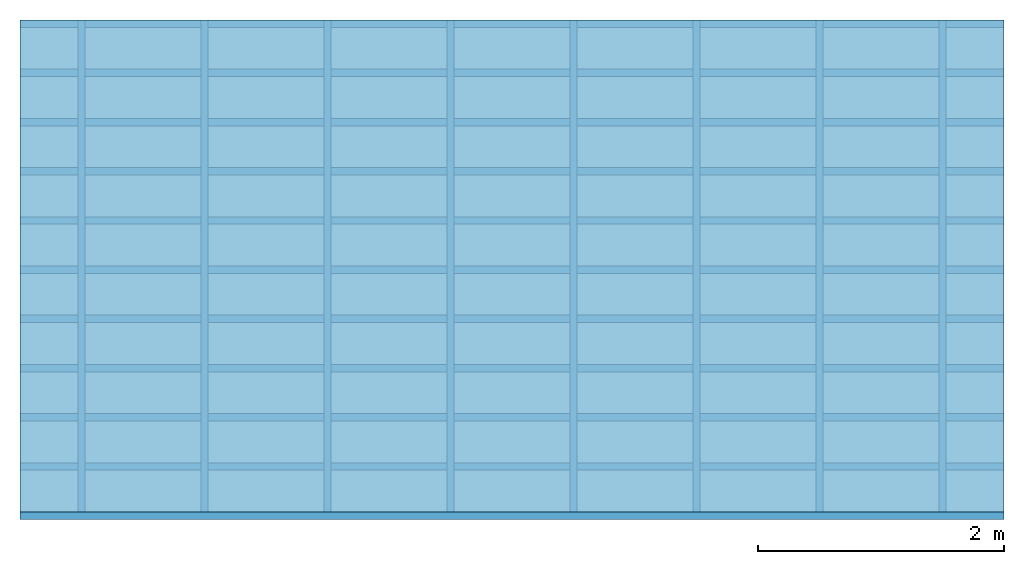
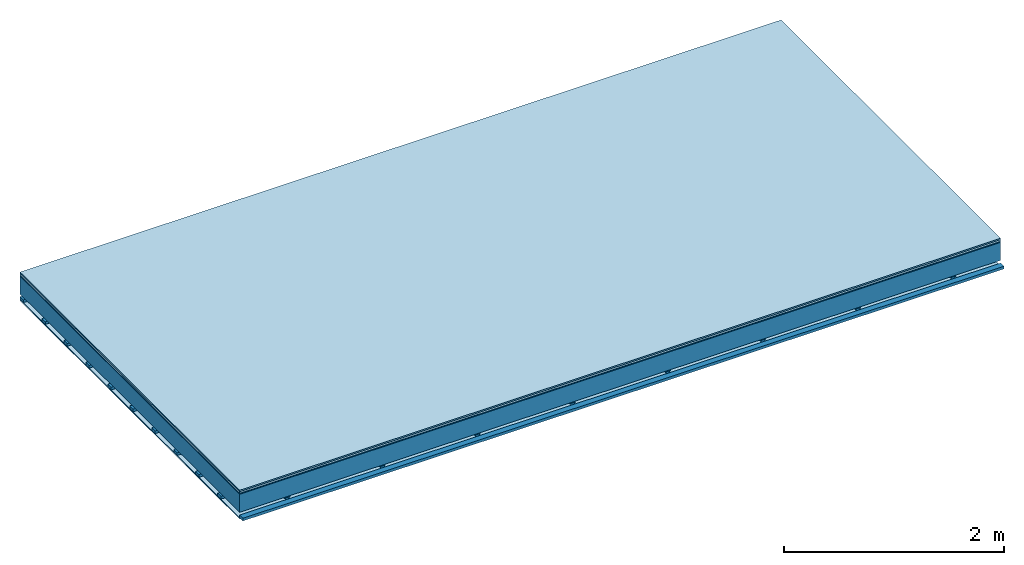
# One storey: 5 plates, 3 members, 1 element without a shape of its own.
"""IFC4 building model written with IfcOpenShell, lengths in metres."""

import ifcopenshell
import ifcopenshell.guid

model = None  # the IFC model being written
_history = None  # IfcOwnerHistory: only IFC2X3 demands one
_inside = {}  # id of a spatial element -> (the spatial element, [elements in it])
_under = {}  # id of a project, library or spatial element -> (it, [spatial elements below it])
_declared = {}  # id of a project -> (the project, [libraries it declares])
_typed = {}  # id of a type object -> (the type object, [elements of that type])
_made_of = {}  # id of a material, layer set ... -> (it, [elements and type objects made of it])


def new_model(schema):
    """Start an empty IFC model of exactly this schema.

    Asked for "IFC4X3", IfcOpenShell would pick the latest addendum, in which some entities
    have other attributes; the version numbers below select the first issue.
    IFC2X3 requires an IfcOwnerHistory on every rooted entity: one is made here for all.
    """
    global model, _history
    if schema == "IFC4X3":
        model = ifcopenshell.file(schema_version=(4, 3, 0, 0))
    else:
        model = ifcopenshell.file(schema=schema)
    _inside.clear()
    _under.clear()
    _declared.clear()
    _typed.clear()
    _made_of.clear()
    _history = None
    if model.schema == "IFC2X3":
        org = make("IfcOrganization", Name="unknown")
        user = make(
            "IfcPersonAndOrganization",
            ThePerson=make("IfcPerson", FamilyName="unknown"),
            TheOrganization=org,
        )
        app = make(
            "IfcApplication",
            ApplicationDeveloper=org,
            Version="unknown",
            ApplicationFullName="unknown",
            ApplicationIdentifier="unknown",
        )
        _history = make(
            "IfcOwnerHistory",
            OwningUser=user,
            OwningApplication=app,
            ChangeAction="ADDED",
            CreationDate=0,
        )
    return model


def make(cls, **values):
    """One entity of the class cls with the attributes given. An attribute that is None is left unset."""
    return model.create_entity(
        cls, **{name: value for name, value in values.items() if value is not None}
    )


def rooted(cls, **values):
    """An entity with a GlobalId (a new one), such as an element, a storey or a relation."""
    return make(cls, GlobalId=ifcopenshell.guid.new(), OwnerHistory=_history, **values)


def si_unit(unit_type, name, prefix=None):
    """IfcSIUnit, for example si_unit("LENGTHUNIT", "METRE", prefix="MILLI")."""
    return make("IfcSIUnit", UnitType=unit_type, Prefix=prefix, Name=name)


def derived_unit(unit_type, elements):
    """IfcDerivedUnit: a product of units, each with its exponent."""
    return make(
        "IfcDerivedUnit",
        Elements=[
            make("IfcDerivedUnitElement", Unit=unit, Exponent=power)
            for unit, power in elements
        ],
        UnitType=unit_type,
    )


def assignment(units):
    """IfcUnitAssignment: the units of a project."""
    return None if units is None else make("IfcUnitAssignment", Units=units)


def point(xyz):
    """IfcCartesianPoint."""
    return None if xyz is None else make("IfcCartesianPoint", Coordinates=xyz)


def direction(xyz):
    """IfcDirection."""
    return None if xyz is None else make("IfcDirection", DirectionRatios=xyz)


def frame(location, z_axis=None, x_axis=None):
    """IfcAxis2Placement3D, a coordinate frame: its origin and axes. An axis left out is left unset."""
    return make(
        "IfcAxis2Placement3D",
        Location=point(location),
        Axis=direction(z_axis),
        RefDirection=direction(x_axis),
    )


def frame_2d(location, x_axis=None):
    """IfcAxis2Placement2D, a coordinate frame in the plane: its origin and x axis."""
    return make(
        "IfcAxis2Placement2D", Location=point(location), RefDirection=direction(x_axis)
    )


def origin():
    """The frame at (0, 0, 0) with its axes left unset."""
    return frame((0.0, 0.0, 0.0))


def origin_with_axes():
    """The frame at (0, 0, 0) with the z axis (0, 0, 1) and the x axis (1, 0, 0) written out."""
    return frame((0.0, 0.0, 0.0), z_axis=(0.0, 0.0, 1.0), x_axis=(1.0, 0.0, 0.0))


def place(relative_to, where):
    """IfcLocalPlacement: puts the frame where relative to a parent placement (None: the world)."""
    return make(
        "IfcLocalPlacement", PlacementRelTo=relative_to, RelativePlacement=where
    )


def context(
    kind, dimensions, precision=None, world=None, true_north=None, identifier=None
):
    """IfcGeometricRepresentationContext, for example the 3D "Model" context."""
    return make(
        "IfcGeometricRepresentationContext",
        ContextIdentifier=identifier,
        ContextType=kind,
        CoordinateSpaceDimension=dimensions,
        Precision=precision,
        WorldCoordinateSystem=world,
        TrueNorth=true_north,
    )


def project(units=None, contexts=None):
    """IfcProject with its units and contexts."""
    return rooted(
        "IfcProject",
        Name="project",
        RepresentationContexts=contexts,
        UnitsInContext=assignment(units),
    )


def spatial(cls, under=None, at=None, **own):
    """A site, building, storey or space (cls), placed at a placement, below another one or the project."""
    s = rooted(cls, ObjectPlacement=at, **own)
    if under is not None:
        _under.setdefault(under.id(), (under, []))[1].append(s)
    return s


def polyline(points):
    """IfcPolyline through the points."""
    return make("IfcPolyline", Points=[point(p) for p in points])


def profile(cls, at=None, kind="AREA", **sizes):
    """A parametric profile (cls). Its sizes go by their IFC names, for example OverallWidth=200.0."""
    return make(cls, ProfileType=kind, Position=at, **sizes)


def rectangle(**sizes):
    """IfcRectangleProfileDef."""
    return profile("IfcRectangleProfileDef", **sizes)


def outline(outer, holes=None, kind="AREA"):
    """IfcArbitraryClosedProfileDef: a profile drawn as a closed curve; with holes, ...WithVoids."""
    if holes is None:
        return make("IfcArbitraryClosedProfileDef", ProfileType=kind, OuterCurve=outer)
    return make(
        "IfcArbitraryProfileDefWithVoids",
        ProfileType=kind,
        OuterCurve=outer,
        InnerCurves=holes,
    )


def extrude(swept, where, along, depth):
    """IfcExtrudedAreaSolid: the profile swept, set in the frame where, extruded along a direction by depth."""
    return make(
        "IfcExtrudedAreaSolid",
        SweptArea=swept,
        Position=where,
        ExtrudedDirection=direction(along),
        Depth=depth,
    )


def shape(context_of_items, identifier, shape_type, items):
    """IfcShapeRepresentation: the items that make up one representation, for example the "Body"."""
    return make(
        "IfcShapeRepresentation",
        ContextOfItems=context_of_items,
        RepresentationIdentifier=identifier,
        RepresentationType=shape_type,
        Items=items,
    )


def material(Name=None, Category=None):
    """IfcMaterial."""
    return make("IfcMaterial", Name=Name, Category=Category)


def layer(
    of_material, thickness, ventilated=None, Name=None, Category=None, Priority=None
):
    """IfcMaterialLayer: one layer of a wall or slab, of a material (None: an air gap)."""
    return make(
        "IfcMaterialLayer",
        Material=of_material,
        LayerThickness=thickness,
        IsVentilated=ventilated,
        Name=Name,
        Category=Category,
        Priority=Priority,
    )


def layer_set(layers, Name=None):
    """IfcMaterialLayerSet."""
    return make("IfcMaterialLayerSet", MaterialLayers=layers, LayerSetName=Name)


def made_of(thing, what):
    """Note that an element or type object is made of a material, layer set ...; save() writes the relation."""
    if what is not None:
        _made_of.setdefault(what.id(), (what, []))[1].append(thing)
    return thing


def type_object(cls, material=None, **own):
    """A type object (cls), such as IfcWallType, which elements share."""
    return made_of(rooted(cls, **own), material)


def element(
    cls,
    number,
    at=None,
    inside=None,
    cuts=None,
    type_object=None,
    material=None,
    context=None,
    identifier="Body",
    shape_type=None,
    held_by="IfcProductDefinitionShape",
    body=None,
    shapes=None,
    **own,
):
    """One element of the class cls, such as IfcWall. Its Tag is "e" and its number.

    at: its placement. inside: the storey or other place that contains it. cuts: it is an
    opening in that element (IfcRelVoidsElement). A single representation is given by context,
    identifier, shape_type and body (its items); several are given by shapes. held_by: the class
    of the entity that holds the representations. save() writes the other relations.
    """
    e = rooted(cls, Tag="e%d" % number, ObjectPlacement=at, **own)
    if body is not None:
        shapes = [shape(context, identifier, shape_type, body)]
    if shapes is not None:
        e.Representation = make(held_by, Representations=shapes)
    if inside is not None:
        _inside.setdefault(inside.id(), (inside, []))[1].append(e)
    if cuts is not None:
        rooted(
            "IfcRelVoidsElement", RelatingBuildingElement=cuts, RelatedOpeningElement=e
        )
    if type_object is not None:
        _typed.setdefault(type_object.id(), (type_object, []))[1].append(e)
    return made_of(e, material)


def aggregate(whole, parts):
    """IfcRelAggregates: a whole, such as a stair, and the parts it consists of."""
    return rooted("IfcRelAggregates", RelatingObject=whole, RelatedObjects=parts)


def save(model, path):
    """Write the relations noted so far, then the file.

    IfcRelAggregates (storeys below a building ...), IfcRelContainedInSpatialStructure (elements
    in a storey), IfcRelDefinesByType, IfcRelAssociatesMaterial and IfcRelDeclares: one each for
    every whole, place, type object, material and project.
    """
    for whole, parts in _under.values():
        aggregate(whole, parts)
    for where, things in _inside.values():
        rooted(
            "IfcRelContainedInSpatialStructure",
            RelatedElements=things,
            RelatingStructure=where,
        )
    for kind, things in _typed.values():
        rooted("IfcRelDefinesByType", RelatedObjects=things, RelatingType=kind)
    for what, things in _made_of.values():
        rooted("IfcRelAssociatesMaterial", RelatedObjects=things, RelatingMaterial=what)
    for by, libraries in _declared.values():
        rooted("IfcRelDeclares", RelatingContext=by, RelatedDefinitions=libraries)
    model.write(path)


model = new_model("IFC4")

# Units and contexts
plan_context = context("Plan", 3, precision=1e-05, world=origin(), true_north=direction((0.0, 1.0)))
model_context = context("Model", 3, precision=1e-05, world=origin(), true_north=direction((0.0, 1.0)))
ifc_project = project(units=[si_unit("LENGTHUNIT", "METRE"), derived_unit("SOUNDPRESSUREUNIT", [(si_unit("PRESSUREUNIT", "PASCAL", prefix="MICRO"), 0)]), si_unit("ENERGYUNIT", "JOULE", prefix="MEGA"), si_unit("MASSUNIT", "GRAM", prefix="KILO"), derived_unit("THERMALTRANSMITTANCEUNIT", [(si_unit("POWERUNIT", "WATT"), 1), (si_unit("AREAUNIT", "SQUARE_METRE"), -1), (si_unit("THERMODYNAMICTEMPERATUREUNIT", "KELVIN"), -1)]), derived_unit("AREADENSITYUNIT", [(si_unit("MASSUNIT", "GRAM", prefix="KILO"), 1), (si_unit("AREAUNIT", "SQUARE_METRE"), -1)]), derived_unit("USERDEFINED", [(si_unit("ENERGYUNIT", "JOULE", prefix="MEGA"), 1), (si_unit("AREAUNIT", "SQUARE_METRE"), -1)])], contexts=[plan_context, model_context])

# Site, building, storey
site = spatial("IfcSite", under=ifc_project)
building_placement = place(None, origin())
building = spatial("IfcBuilding", under=site, at=building_placement)
storey_placement = place(building_placement, origin())
storey = spatial("IfcBuildingStorey", under=building, at=storey_placement)

# Slab, members, plates
ifc_material_1 = material(Category="11.013")
ifc_layer_1 = layer(ifc_material_1, 0.015, Name="Flooring")
ifc_material_2 = material(Category="03.007")
ifc_layer_2 = layer(ifc_material_2, 0.02, Name="On-material")
ifc_material_3 = material(Name="Wood fiber generic product", Category="10.009")
ifc_layer_3 = layer(ifc_material_3, 0.01, Name="Impact sound insulation")
ifc_material_4 = material(Name="no composite action")
ifc_layer_4 = layer(ifc_material_4, 0.0, Name="Bond")
ifc_layer_5 = layer(None, 0.2, Name="Supporting structure")
ifc_layer_6 = layer(ifc_material_4, 0.0, Name="Bond")
ifc_layer_7 = layer(None, 0.03, Name="Coupling")
ifc_layer_8 = layer(None, 0.03, Name="Battens / profiles")
ifc_material_5 = material(Name="Plasterboard type A", Category="03.008")
ifc_layer_9 = layer(ifc_material_5, 0.0125, Name="Ceiling covering 1st layer")
ifc_material_6 = material(Category="04.001")
ifc_layer_10 = layer(ifc_material_6, 0.003, Name="Surface / treatment")
ifc_layer_set = layer_set([ifc_layer_1, ifc_layer_2, ifc_layer_3, ifc_layer_4, ifc_layer_5, ifc_layer_6, ifc_layer_7, ifc_layer_8, ifc_layer_9, ifc_layer_10])
slab_type = type_object("IfcSlabType", Name="A2100", PredefinedType="NOTDEFINED", material=ifc_layer_set)
slab_placement = place(None, frame((0.0, 0.0, 0.0), z_axis=(0.0, 0.0, -1.0), x_axis=(1.0, 0.0, 0.0)))
slab = element("IfcSlab", 1, at=slab_placement, inside=storey, type_object=slab_type, material=ifc_layer_set, Name="Slab #1")
ifc_material_7 = material(Name="Solid timber panel")
member_1_placement = place(slab_placement, origin())
member_1 = element("IfcMember", 2, at=member_1_placement, material=ifc_material_7, Name="Supporting structure", context=plan_context, shape_type="SweptSolid", body=[
    extrude(rectangle(XDim=1.0, YDim=0.2, at=frame_2d((0.5, 0.1), x_axis=(1.0, 0.0))), frame((0.0, 4.0, 0.045), z_axis=(0.0, -1.0, 0.0), x_axis=(1.0, 0.0, 0.0)), (0.0, 0.0, 1.0), 4.0),
    extrude(rectangle(XDim=1.0, YDim=0.2, at=frame_2d((0.5, 0.1), x_axis=(1.0, 0.0))), frame((1.0, 4.0, 0.045), z_axis=(0.0, -1.0, 0.0), x_axis=(1.0, 0.0, 0.0)), (0.0, 0.0, 1.0), 4.0),
    extrude(rectangle(XDim=1.0, YDim=0.2, at=frame_2d((0.5, 0.1), x_axis=(1.0, 0.0))), frame((2.0, 4.0, 0.045), z_axis=(0.0, -1.0, 0.0), x_axis=(1.0, 0.0, 0.0)), (0.0, 0.0, 1.0), 4.0),
    extrude(rectangle(XDim=1.0, YDim=0.2, at=frame_2d((0.5, 0.1), x_axis=(1.0, 0.0))), frame((3.0, 4.0, 0.045), z_axis=(0.0, -1.0, 0.0), x_axis=(1.0, 0.0, 0.0)), (0.0, 0.0, 1.0), 4.0),
    extrude(rectangle(XDim=1.0, YDim=0.2, at=frame_2d((0.5, 0.1), x_axis=(1.0, 0.0))), frame((4.0, 4.0, 0.045), z_axis=(0.0, -1.0, 0.0), x_axis=(1.0, 0.0, 0.0)), (0.0, 0.0, 1.0), 4.0),
    extrude(rectangle(XDim=1.0, YDim=0.2, at=frame_2d((0.5, 0.1), x_axis=(1.0, 0.0))), frame((5.0, 4.0, 0.045), z_axis=(0.0, -1.0, 0.0), x_axis=(1.0, 0.0, 0.0)), (0.0, 0.0, 1.0), 4.0),
    extrude(rectangle(XDim=1.0, YDim=0.2, at=frame_2d((0.5, 0.1), x_axis=(1.0, 0.0))), frame((6.0, 4.0, 0.045), z_axis=(0.0, -1.0, 0.0), x_axis=(1.0, 0.0, 0.0)), (0.0, 0.0, 1.0), 4.0),
    extrude(rectangle(XDim=1.0, YDim=0.2, at=frame_2d((0.5, 0.1), x_axis=(1.0, 0.0))), frame((7.0, 4.0, 0.045), z_axis=(0.0, -1.0, 0.0), x_axis=(1.0, 0.0, 0.0)), (0.0, 0.0, 1.0), 4.0),
])
ifc_material_8 = material()
member_2_placement = place(slab_placement, origin())
member_2 = element("IfcMember", 3, at=member_2_placement, material=ifc_material_8, Name="Coupling", context=plan_context, shape_type="SweptSolid", body=[
    extrude(outline(polyline([(0.0, 0.0), (0.06, 0.0), (0.04, 0.02), (0.02, 0.02), (0.0, 0.0)])), frame((0.47, 4.0, 0.255), z_axis=(0.0, -1.0, 0.0), x_axis=(1.0, 0.0, 0.0)), (0.0, 0.0, 1.0), 4.0),
    extrude(outline(polyline([(0.0, 0.0), (0.06, 0.0), (0.04, 0.02), (0.02, 0.02), (0.0, 0.0)])), frame((1.47, 4.0, 0.255), z_axis=(0.0, -1.0, 0.0), x_axis=(1.0, 0.0, 0.0)), (0.0, 0.0, 1.0), 4.0),
    extrude(outline(polyline([(0.0, 0.0), (0.06, 0.0), (0.04, 0.02), (0.02, 0.02), (0.0, 0.0)])), frame((2.47, 4.0, 0.255), z_axis=(0.0, -1.0, 0.0), x_axis=(1.0, 0.0, 0.0)), (0.0, 0.0, 1.0), 4.0),
    extrude(outline(polyline([(0.0, 0.0), (0.06, 0.0), (0.04, 0.02), (0.02, 0.02), (0.0, 0.0)])), frame((3.47, 4.0, 0.255), z_axis=(0.0, -1.0, 0.0), x_axis=(1.0, 0.0, 0.0)), (0.0, 0.0, 1.0), 4.0),
    extrude(outline(polyline([(0.0, 0.0), (0.06, 0.0), (0.04, 0.02), (0.02, 0.02), (0.0, 0.0)])), frame((4.47, 4.0, 0.255), z_axis=(0.0, -1.0, 0.0), x_axis=(1.0, 0.0, 0.0)), (0.0, 0.0, 1.0), 4.0),
    extrude(outline(polyline([(0.0, 0.0), (0.06, 0.0), (0.04, 0.02), (0.02, 0.02), (0.0, 0.0)])), frame((5.47, 4.0, 0.255), z_axis=(0.0, -1.0, 0.0), x_axis=(1.0, 0.0, 0.0)), (0.0, 0.0, 1.0), 4.0),
    extrude(outline(polyline([(0.0, 0.0), (0.06, 0.0), (0.04, 0.02), (0.02, 0.02), (0.0, 0.0)])), frame((6.47, 4.0, 0.255), z_axis=(0.0, -1.0, 0.0), x_axis=(1.0, 0.0, 0.0)), (0.0, 0.0, 1.0), 4.0),
    extrude(outline(polyline([(0.0, 0.0), (0.06, 0.0), (0.04, 0.02), (0.02, 0.02), (0.0, 0.0)])), frame((7.47, 4.0, 0.255), z_axis=(0.0, -1.0, 0.0), x_axis=(1.0, 0.0, 0.0)), (0.0, 0.0, 1.0), 4.0),
])
member_3_placement = place(slab_placement, origin())
member_3 = element("IfcMember", 4, at=member_3_placement, material=ifc_material_8, Name="Battens / profiles", context=plan_context, shape_type="SweptSolid", body=[
    extrude(rectangle(XDim=0.06, YDim=0.03, at=frame_2d((0.03, 0.015), x_axis=(1.0, 0.0))), frame((0.0, 0.0, 0.275), z_axis=(1.0, 0.0, 0.0), x_axis=(0.0, 1.0, 0.0)), (0.0, 0.0, 1.0), 8.0),
    extrude(rectangle(XDim=0.06, YDim=0.03, at=frame_2d((0.03, 0.015), x_axis=(1.0, 0.0))), frame((0.0, 0.4, 0.275), z_axis=(1.0, 0.0, 0.0), x_axis=(0.0, 1.0, 0.0)), (0.0, 0.0, 1.0), 8.0),
    extrude(rectangle(XDim=0.06, YDim=0.03, at=frame_2d((0.03, 0.015), x_axis=(1.0, 0.0))), frame((0.0, 0.8, 0.275), z_axis=(1.0, 0.0, 0.0), x_axis=(0.0, 1.0, 0.0)), (0.0, 0.0, 1.0), 8.0),
    extrude(rectangle(XDim=0.06, YDim=0.03, at=frame_2d((0.03, 0.015), x_axis=(1.0, 0.0))), frame((0.0, 1.2, 0.275), z_axis=(1.0, 0.0, 0.0), x_axis=(0.0, 1.0, 0.0)), (0.0, 0.0, 1.0), 8.0),
    extrude(rectangle(XDim=0.06, YDim=0.03, at=frame_2d((0.03, 0.015), x_axis=(1.0, 0.0))), frame((0.0, 1.6, 0.275), z_axis=(1.0, 0.0, 0.0), x_axis=(0.0, 1.0, 0.0)), (0.0, 0.0, 1.0), 8.0),
    extrude(rectangle(XDim=0.06, YDim=0.03, at=frame_2d((0.03, 0.015), x_axis=(1.0, 0.0))), frame((0.0, 2.0, 0.275), z_axis=(1.0, 0.0, 0.0), x_axis=(0.0, 1.0, 0.0)), (0.0, 0.0, 1.0), 8.0),
    extrude(rectangle(XDim=0.06, YDim=0.03, at=frame_2d((0.03, 0.015), x_axis=(1.0, 0.0))), frame((0.0, 2.4, 0.275), z_axis=(1.0, 0.0, 0.0), x_axis=(0.0, 1.0, 0.0)), (0.0, 0.0, 1.0), 8.0),
    extrude(rectangle(XDim=0.06, YDim=0.03, at=frame_2d((0.03, 0.015), x_axis=(1.0, 0.0))), frame((0.0, 2.8, 0.275), z_axis=(1.0, 0.0, 0.0), x_axis=(0.0, 1.0, 0.0)), (0.0, 0.0, 1.0), 8.0),
    extrude(rectangle(XDim=0.06, YDim=0.03, at=frame_2d((0.03, 0.015), x_axis=(1.0, 0.0))), frame((0.0, 3.2, 0.275), z_axis=(1.0, 0.0, 0.0), x_axis=(0.0, 1.0, 0.0)), (0.0, 0.0, 1.0), 8.0),
    extrude(rectangle(XDim=0.06, YDim=0.03, at=frame_2d((0.03, 0.015), x_axis=(1.0, 0.0))), frame((0.0, 3.6, 0.275), z_axis=(1.0, 0.0, 0.0), x_axis=(0.0, 1.0, 0.0)), (0.0, 0.0, 1.0), 8.0),
    extrude(rectangle(XDim=0.06, YDim=0.03, at=frame_2d((0.03, 0.015), x_axis=(1.0, 0.0))), frame((0.0, 4.0, 0.275), z_axis=(1.0, 0.0, 0.0), x_axis=(0.0, 1.0, 0.0)), (0.0, 0.0, 1.0), 8.0),
])
plate_1_placement = place(slab_placement, origin())
plate_1 = element("IfcPlate", 5, at=plate_1_placement, material=ifc_material_1, Name="Flooring", context=plan_context, shape_type="SweptSolid", body=[
    extrude(rectangle(XDim=8.0, YDim=4.0, at=frame_2d((4.0, 2.0), x_axis=(1.0, 0.0))), origin_with_axes(), (0.0, 0.0, 1.0), 0.015),
])
plate_2_placement = place(slab_placement, origin())
plate_2 = element("IfcPlate", 6, at=plate_2_placement, material=ifc_material_2, Name="On-material", context=plan_context, shape_type="SweptSolid", body=[
    extrude(rectangle(XDim=8.0, YDim=4.0, at=frame_2d((4.0, 2.0), x_axis=(1.0, 0.0))), frame((0.0, 0.0, 0.015), z_axis=(0.0, 0.0, 1.0), x_axis=(1.0, 0.0, 0.0)), (0.0, 0.0, 1.0), 0.02),
])
plate_3_placement = place(slab_placement, origin())
plate_3 = element("IfcPlate", 7, at=plate_3_placement, material=ifc_material_3, Name="Impact sound insulation", context=plan_context, shape_type="SweptSolid", body=[
    extrude(rectangle(XDim=8.0, YDim=4.0, at=frame_2d((4.0, 2.0), x_axis=(1.0, 0.0))), frame((0.0, 0.0, 0.035), z_axis=(0.0, 0.0, 1.0), x_axis=(1.0, 0.0, 0.0)), (0.0, 0.0, 1.0), 0.01),
])
plate_4_placement = place(slab_placement, origin())
plate_4 = element("IfcPlate", 8, at=plate_4_placement, material=ifc_material_5, Name="Ceiling covering 1st layer", context=plan_context, shape_type="SweptSolid", body=[
    extrude(rectangle(XDim=8.0, YDim=4.0, at=frame_2d((4.0, 2.0), x_axis=(1.0, 0.0))), frame((0.0, 0.0, 0.305), z_axis=(0.0, 0.0, 1.0), x_axis=(1.0, 0.0, 0.0)), (0.0, 0.0, 1.0), 0.0125),
])
plate_5_placement = place(slab_placement, origin())
plate_5 = element("IfcPlate", 9, at=plate_5_placement, material=ifc_material_6, Name="Surface / treatment", context=plan_context, shape_type="SweptSolid", body=[
    extrude(rectangle(XDim=8.0, YDim=4.0, at=frame_2d((4.0, 2.0), x_axis=(1.0, 0.0))), frame((0.0, 0.0, 0.3175), z_axis=(0.0, 0.0, 1.0), x_axis=(1.0, 0.0, 0.0)), (0.0, 0.0, 1.0), 0.003),
])
aggregate(slab, [plate_1, plate_2, plate_3, member_1, member_2, member_3, plate_4, plate_5])

save(model, "model.ifc")
